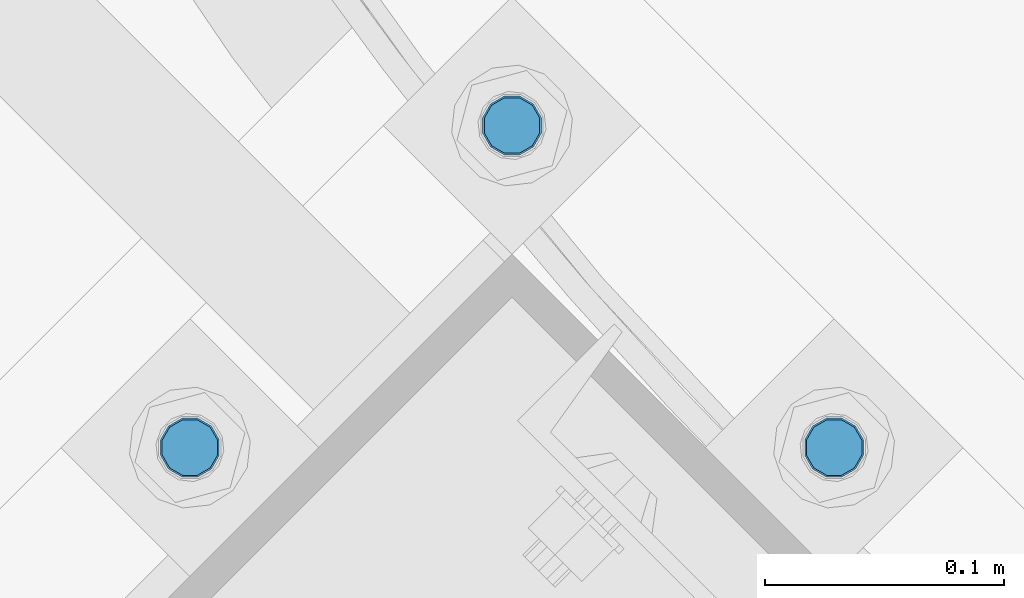
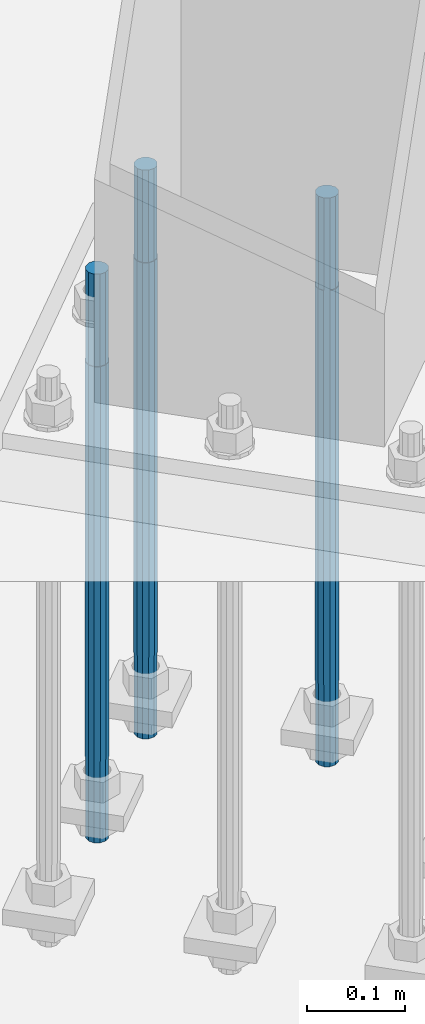
# One storey, part 781 of 1876: 3 columns, 1 element without a shape of its own.
"""IFC2X3 building model written with IfcOpenShell, lengths in millimetres."""

from ifc_helpers import new_model, si_unit, frame, origin_with_axes, place, context, subcontext, project, spatial, faceted_brep, material, type_object, element, aggregate, save


model = new_model("IFC2X3")

# Units and contexts
model_context = context("Model", 3, precision=1e-05, world=origin_with_axes())
body_context = subcontext(model_context, "Body", "Model", "MODEL_VIEW")
ifc_project = project(units=[si_unit("LENGTHUNIT", "METRE", prefix="MILLI"), si_unit("AREAUNIT", "SQUARE_METRE"), si_unit("VOLUMEUNIT", "CUBIC_METRE"), si_unit("MASSUNIT", "GRAM", prefix="KILO"), si_unit("TIMEUNIT", "SECOND"), si_unit("PLANEANGLEUNIT", "RADIAN"), si_unit("SOLIDANGLEUNIT", "STERADIAN"), si_unit("THERMODYNAMICTEMPERATUREUNIT", "DEGREE_CELSIUS"), si_unit("LUMINOUSINTENSITYUNIT", "LUMEN")], contexts=[model_context])

# Site, building, storey
site_placement = place(None, origin_with_axes())
site = spatial("IfcSite", under=ifc_project, at=site_placement, CompositionType="ELEMENT")
building_placement = place(site_placement, origin_with_axes())
building = spatial("IfcBuilding", under=site, at=building_placement, Name="Undefined", CompositionType="ELEMENT")
storey_placement = place(building_placement, origin_with_axes())
storey = spatial("IfcBuildingStorey", under=building, at=storey_placement, Name="Undefined", CompositionType="ELEMENT", Elevation=0.0)

# Assembly, columns
assembly_placement = place(storey_placement, origin_with_axes())
assembly = element("IfcElementAssembly", 1, at=assembly_placement, inside=storey, Name="TEMPLATE", AssemblyPlace="NOTDEFINED", PredefinedType="RIGID_FRAME")
ifc_material = material(Name="STEEL/F1554-GR.105")
column_type = type_object("IfcColumnType", PredefinedType="NOTDEFINED")
column_1_placement = place(assembly_placement, frame((3917.62601588898, -14852.9739841116, 7.105427357601e-15), z_axis=(0.707106781186548, 0.707106781186547, 0.0), x_axis=(0.0, 0.0, -1.0)))
column_1 = element("IfcColumn", 2, at=column_1_placement, type_object=column_type, material=ifc_material, Name="ANCHOR_BOLTS", context=body_context, shape_type="Brep", body=[
    faceted_brep([(-114.3, -10.3923048454853, 6.0000000001337), (-114.3, -6.00000000006912, 10.3923048455481), (-114.3, -6.54836185276508e-11, 12.0000000001355), (-114.3, 5.99999999993634, 10.3923048455481), (-114.3, 10.3923048453526, 6.00000000013279), (-114.3, 11.9999999999418, 1.29148247651756e-10), (-114.3, 10.3923048453507, -5.99999999987358), (-114.3, 5.99999999993815, -10.392304845288), (-114.3, -6.54836185276508e-11, -11.9999999998781), (-114.3, -6.00000000006912, -10.3923048452889), (-114.3, -10.3923048454853, -5.99999999987358), (-114.3, -12.0000000000728, 1.28238752949983e-10), (0.0, 11.9999999999418, 1.29148247651756e-10), (0.0, 10.3923048453507, -5.99999999987358), (0.0, 5.99999999993815, -10.392304845288), (0.0, -6.54836185276508e-11, -11.9999999998781), (0.0, -6.00000000006912, -10.3923048452889), (0.0, -10.3923048454853, -5.99999999987358), (0.0, -12.0000000000728, 1.28238752949983e-10), (0.0, -10.3923048454853, 6.0000000001337), (0.0, -6.00000000006912, 10.3923048455481), (0.0, -6.54836185276508e-11, 12.0000000001355), (0.0, 5.99999999993634, 10.3923048455481), (0.0, 10.3923048453526, 6.00000000013279), (0.0, -10.998522628066, 6.35000000000218), (0.0, -6.35000000000218, 10.9985226280642), (0.0, 0.0, 12.7000000000035), (0.0, 6.34999999999854, 10.9985226280651), (0.0, 10.9985226280623, 6.35000000000218), (0.0, 12.6999999999998, 0.0), (0.0, 10.9985226280623, -6.35000000000127), (0.0, 6.34999999999854, -10.9985226280633), (0.0, 0.0, -12.7000000000016), (0.0, -6.35000000000218, -10.9985226280642), (0.0, -10.998522628066, -6.35000000000127), (0.0, -12.6999999999998, 0.0), (488.95, -12.7000000000044, 9.09494701772928e-13), (488.95, -10.998522628066, 6.35000000000218), (488.95, -6.35000000000218, 10.9985226280642), (488.95, 0.0, 12.7000000000035), (488.95, 6.34999999999854, 10.9985226280651), (488.95, 10.9985226280623, 6.35000000000218), (488.95, 12.7000000000007, 9.09494701772928e-13), (488.95, 10.9985226280623, -6.35000000000127), (488.95, 6.34999999999854, -10.9985226280633), (488.95, 0.0, -12.7000000000016), (488.95, -6.35000000000218, -10.9985226280642), (488.95, -10.998522628066, -6.35000000000127), (488.95, -6.00000000006912, 10.3923048455481), (488.95, -6.54836185276508e-11, 12.0000000001355), (488.95, 5.99999999993634, 10.3923048455481), (488.95, 10.3923048453526, 6.00000000013279), (488.95, 11.9999999999418, 1.29148247651756e-10), (488.95, 10.3923048453507, -5.99999999987358), (488.95, 5.99999999993815, -10.392304845288), (488.95, -6.54836185276508e-11, -11.9999999998781), (488.95, -6.00000000006912, -10.3923048452889), (488.95, -10.3923048454853, -5.99999999987358), (488.95, -12.0000000000728, 1.28238752949983e-10), (488.95, -10.3923048454853, 6.0000000001337), (590.55, -6.00000000006912, -10.3923048452889), (590.55, -6.54836185276508e-11, -11.9999999998781), (590.55, 5.99999999993815, -10.392304845288), (590.55, 10.3923048453507, -5.99999999987358), (590.55, 11.9999999999418, 1.29148247651756e-10), (590.55, 10.3923048453526, 6.00000000013279), (590.55, 5.99999999993634, 10.3923048455481), (590.55, -6.54836185276508e-11, 12.0000000001355), (590.55, -6.00000000006912, 10.3923048455481), (590.55, -10.3923048454853, 6.0000000001337), (590.55, -12.0000000000728, 1.28238752949983e-10), (590.55, -10.3923048454853, -5.99999999987358)], [[[0, 1, 2, 3, 4, 5, 6, 7, 8, 9, 10, 11]], [[6, 5, 12, 13]], [[7, 6, 13, 14]], [[8, 7, 14, 15]], [[9, 8, 15, 16]], [[10, 9, 16, 17]], [[11, 10, 17, 18]], [[0, 11, 18, 19]], [[1, 0, 19, 20]], [[2, 1, 20, 21]], [[3, 2, 21, 22]], [[4, 3, 22, 23]], [[5, 4, 23, 12]], [[24, 25, 26, 27, 28, 29, 30, 31, 32, 33, 34, 35], [22, 21, 20, 19, 18, 17, 16, 15, 14, 13, 12, 23]], [[24, 35, 36, 37]], [[25, 24, 37, 38]], [[26, 25, 38, 39]], [[27, 26, 39, 40]], [[28, 27, 40, 41]], [[29, 28, 41, 42]], [[30, 29, 42, 43]], [[31, 30, 43, 44]], [[32, 31, 44, 45]], [[33, 32, 45, 46]], [[34, 33, 46, 47]], [[35, 34, 47, 36]], [[46, 45, 44, 43, 42, 41, 40, 39, 38, 37, 36, 47], [48, 49, 50, 51, 52, 53, 54, 55, 56, 57, 58, 59]], [[60, 61, 62, 63, 64, 65, 66, 67, 68, 69, 70, 71]], [[68, 67, 49, 48]], [[69, 68, 48, 59]], [[70, 69, 59, 58]], [[71, 70, 58, 57]], [[60, 71, 57, 56]], [[61, 60, 56, 55]], [[62, 61, 55, 54]], [[63, 62, 54, 53]], [[64, 63, 53, 52]], [[65, 64, 52, 51]], [[66, 65, 51, 50]], [[67, 66, 50, 49]]]),
])
column_2_placement = place(assembly_placement, frame((3782.9221740726, -14718.2701422952, 7.105427357601e-15), z_axis=(-0.707106781186547, -0.707106781186548, 0.0), x_axis=(0.0, 0.0, -1.0)))
column_2 = element("IfcColumn", 3, at=column_2_placement, type_object=column_type, material=ifc_material, Name="ANCHOR_BOLTS", context=body_context, shape_type="Brep", body=[
    faceted_brep([(-114.3, -10.3923048454853, 6.0000000001337), (-114.3, -6.00000000006912, 10.3923048455481), (-114.3, -6.54836185276508e-11, 12.0000000001355), (-114.3, 5.99999999993634, 10.3923048455481), (-114.3, 10.3923048453526, 6.00000000013279), (-114.3, 11.9999999999418, 1.29148247651756e-10), (-114.3, 10.3923048453507, -5.99999999987358), (-114.3, 5.99999999993815, -10.392304845288), (-114.3, -6.54836185276508e-11, -11.9999999998781), (-114.3, -6.00000000006912, -10.3923048452889), (-114.3, -10.3923048454853, -5.99999999987358), (-114.3, -12.0000000000728, 1.28238752949983e-10), (0.0, 11.9999999999418, 1.29148247651756e-10), (0.0, 10.3923048453507, -5.99999999987358), (0.0, 5.99999999993815, -10.392304845288), (0.0, -6.54836185276508e-11, -11.9999999998781), (0.0, -6.00000000006912, -10.3923048452889), (0.0, -10.3923048454853, -5.99999999987358), (0.0, -12.0000000000728, 1.28238752949983e-10), (0.0, -10.3923048454853, 6.0000000001337), (0.0, -6.00000000006912, 10.3923048455481), (0.0, -6.54836185276508e-11, 12.0000000001355), (0.0, 5.99999999993634, 10.3923048455481), (0.0, 10.3923048453526, 6.00000000013279), (0.0, -10.998522628066, 6.35000000000218), (0.0, -6.35000000000218, 10.9985226280642), (0.0, 0.0, 12.7000000000035), (0.0, 6.34999999999854, 10.9985226280651), (0.0, 10.9985226280623, 6.35000000000218), (0.0, 12.6999999999998, 0.0), (0.0, 10.9985226280623, -6.35000000000127), (0.0, 6.34999999999854, -10.9985226280633), (0.0, 0.0, -12.7000000000016), (0.0, -6.35000000000218, -10.9985226280642), (0.0, -10.998522628066, -6.35000000000127), (0.0, -12.6999999999998, 0.0), (488.95, -12.7000000000044, 9.09494701772928e-13), (488.95, -10.998522628066, 6.35000000000218), (488.95, -6.35000000000218, 10.9985226280642), (488.95, 0.0, 12.7000000000035), (488.95, 6.34999999999854, 10.9985226280651), (488.95, 10.9985226280623, 6.35000000000218), (488.95, 12.7000000000007, 9.09494701772928e-13), (488.95, 10.9985226280623, -6.35000000000127), (488.95, 6.34999999999854, -10.9985226280633), (488.95, 0.0, -12.7000000000016), (488.95, -6.35000000000218, -10.9985226280642), (488.95, -10.998522628066, -6.35000000000127), (488.95, -6.00000000006912, 10.3923048455481), (488.95, -6.54836185276508e-11, 12.0000000001355), (488.95, 5.99999999993634, 10.3923048455481), (488.95, 10.3923048453526, 6.00000000013279), (488.95, 11.9999999999418, 1.29148247651756e-10), (488.95, 10.3923048453507, -5.99999999987358), (488.95, 5.99999999993815, -10.392304845288), (488.95, -6.54836185276508e-11, -11.9999999998781), (488.95, -6.00000000006912, -10.3923048452889), (488.95, -10.3923048454853, -5.99999999987358), (488.95, -12.0000000000728, 1.28238752949983e-10), (488.95, -10.3923048454853, 6.0000000001337), (590.55, -6.00000000006912, -10.3923048452889), (590.55, -6.54836185276508e-11, -11.9999999998781), (590.55, 5.99999999993815, -10.392304845288), (590.55, 10.3923048453507, -5.99999999987358), (590.55, 11.9999999999418, 1.29148247651756e-10), (590.55, 10.3923048453526, 6.00000000013279), (590.55, 5.99999999993634, 10.3923048455481), (590.55, -6.54836185276508e-11, 12.0000000001355), (590.55, -6.00000000006912, 10.3923048455481), (590.55, -10.3923048454853, 6.0000000001337), (590.55, -12.0000000000728, 1.28238752949983e-10), (590.55, -10.3923048454853, -5.99999999987358)], [[[0, 1, 2, 3, 4, 5, 6, 7, 8, 9, 10, 11]], [[6, 5, 12, 13]], [[7, 6, 13, 14]], [[8, 7, 14, 15]], [[9, 8, 15, 16]], [[10, 9, 16, 17]], [[11, 10, 17, 18]], [[0, 11, 18, 19]], [[1, 0, 19, 20]], [[2, 1, 20, 21]], [[3, 2, 21, 22]], [[4, 3, 22, 23]], [[5, 4, 23, 12]], [[24, 25, 26, 27, 28, 29, 30, 31, 32, 33, 34, 35], [22, 21, 20, 19, 18, 17, 16, 15, 14, 13, 12, 23]], [[24, 35, 36, 37]], [[25, 24, 37, 38]], [[26, 25, 38, 39]], [[27, 26, 39, 40]], [[28, 27, 40, 41]], [[29, 28, 41, 42]], [[30, 29, 42, 43]], [[31, 30, 43, 44]], [[32, 31, 44, 45]], [[33, 32, 45, 46]], [[34, 33, 46, 47]], [[35, 34, 47, 36]], [[46, 45, 44, 43, 42, 41, 40, 39, 38, 37, 36, 47], [48, 49, 50, 51, 52, 53, 54, 55, 56, 57, 58, 59]], [[60, 61, 62, 63, 64, 65, 66, 67, 68, 69, 70, 71]], [[68, 67, 49, 48]], [[69, 68, 48, 59]], [[70, 69, 59, 58]], [[71, 70, 58, 57]], [[60, 71, 57, 56]], [[61, 60, 56, 55]], [[62, 61, 55, 54]], [[63, 62, 54, 53]], [[64, 63, 53, 52]], [[65, 64, 52, 51]], [[66, 65, 51, 50]], [[67, 66, 50, 49]]]),
])
column_3_placement = place(assembly_placement, frame((3648.21833225621, -14852.9739841116, 7.105427357601e-15), z_axis=(-0.707106781186547, -0.707106781186548, 0.0), x_axis=(0.0, 0.0, -1.0)))
column_3 = element("IfcColumn", 4, at=column_3_placement, type_object=column_type, material=ifc_material, Name="ANCHOR_BOLTS", context=body_context, shape_type="Brep", body=[
    faceted_brep([(-114.3, -10.3923048454853, 6.0000000001337), (-114.3, -6.00000000006912, 10.3923048455481), (-114.3, -6.54836185276508e-11, 12.0000000001355), (-114.3, 5.99999999993634, 10.3923048455481), (-114.3, 10.3923048453526, 6.00000000013279), (-114.3, 11.9999999999418, 1.29148247651756e-10), (-114.3, 10.3923048453507, -5.99999999987358), (-114.3, 5.99999999993815, -10.392304845288), (-114.3, -6.54836185276508e-11, -11.9999999998781), (-114.3, -6.00000000006912, -10.3923048452889), (-114.3, -10.3923048454853, -5.99999999987358), (-114.3, -12.0000000000728, 1.28238752949983e-10), (0.0, 11.9999999999418, 1.29148247651756e-10), (0.0, 10.3923048453507, -5.99999999987358), (0.0, 5.99999999993815, -10.392304845288), (0.0, -6.54836185276508e-11, -11.9999999998781), (0.0, -6.00000000006912, -10.3923048452889), (0.0, -10.3923048454853, -5.99999999987358), (0.0, -12.0000000000728, 1.28238752949983e-10), (0.0, -10.3923048454853, 6.0000000001337), (0.0, -6.00000000006912, 10.3923048455481), (0.0, -6.54836185276508e-11, 12.0000000001355), (0.0, 5.99999999993634, 10.3923048455481), (0.0, 10.3923048453526, 6.00000000013279), (0.0, -10.998522628066, 6.35000000000218), (0.0, -6.35000000000218, 10.9985226280642), (0.0, 0.0, 12.7000000000035), (0.0, 6.34999999999854, 10.9985226280651), (0.0, 10.9985226280623, 6.35000000000218), (0.0, 12.6999999999998, 0.0), (0.0, 10.9985226280623, -6.35000000000127), (0.0, 6.34999999999854, -10.9985226280633), (0.0, 0.0, -12.7000000000016), (0.0, -6.35000000000218, -10.9985226280642), (0.0, -10.998522628066, -6.35000000000127), (0.0, -12.6999999999998, 0.0), (488.95, -12.7000000000044, 9.09494701772928e-13), (488.95, -10.998522628066, 6.35000000000218), (488.95, -6.35000000000218, 10.9985226280642), (488.95, 0.0, 12.7000000000035), (488.95, 6.34999999999854, 10.9985226280651), (488.95, 10.9985226280623, 6.35000000000218), (488.95, 12.7000000000007, 9.09494701772928e-13), (488.95, 10.9985226280623, -6.35000000000127), (488.95, 6.34999999999854, -10.9985226280633), (488.95, 0.0, -12.7000000000016), (488.95, -6.35000000000218, -10.9985226280642), (488.95, -10.998522628066, -6.35000000000127), (488.95, -6.00000000006912, 10.3923048455481), (488.95, -6.54836185276508e-11, 12.0000000001355), (488.95, 5.99999999993634, 10.3923048455481), (488.95, 10.3923048453526, 6.00000000013279), (488.95, 11.9999999999418, 1.29148247651756e-10), (488.95, 10.3923048453507, -5.99999999987358), (488.95, 5.99999999993815, -10.392304845288), (488.95, -6.54836185276508e-11, -11.9999999998781), (488.95, -6.00000000006912, -10.3923048452889), (488.95, -10.3923048454853, -5.99999999987358), (488.95, -12.0000000000728, 1.28238752949983e-10), (488.95, -10.3923048454853, 6.0000000001337), (590.55, -6.00000000006912, -10.3923048452889), (590.55, -6.54836185276508e-11, -11.9999999998781), (590.55, 5.99999999993815, -10.392304845288), (590.55, 10.3923048453507, -5.99999999987358), (590.55, 11.9999999999418, 1.29148247651756e-10), (590.55, 10.3923048453526, 6.00000000013279), (590.55, 5.99999999993634, 10.3923048455481), (590.55, -6.54836185276508e-11, 12.0000000001355), (590.55, -6.00000000006912, 10.3923048455481), (590.55, -10.3923048454853, 6.0000000001337), (590.55, -12.0000000000728, 1.28238752949983e-10), (590.55, -10.3923048454853, -5.99999999987358)], [[[0, 1, 2, 3, 4, 5, 6, 7, 8, 9, 10, 11]], [[6, 5, 12, 13]], [[7, 6, 13, 14]], [[8, 7, 14, 15]], [[9, 8, 15, 16]], [[10, 9, 16, 17]], [[11, 10, 17, 18]], [[0, 11, 18, 19]], [[1, 0, 19, 20]], [[2, 1, 20, 21]], [[3, 2, 21, 22]], [[4, 3, 22, 23]], [[5, 4, 23, 12]], [[24, 25, 26, 27, 28, 29, 30, 31, 32, 33, 34, 35], [22, 21, 20, 19, 18, 17, 16, 15, 14, 13, 12, 23]], [[24, 35, 36, 37]], [[25, 24, 37, 38]], [[26, 25, 38, 39]], [[27, 26, 39, 40]], [[28, 27, 40, 41]], [[29, 28, 41, 42]], [[30, 29, 42, 43]], [[31, 30, 43, 44]], [[32, 31, 44, 45]], [[33, 32, 45, 46]], [[34, 33, 46, 47]], [[35, 34, 47, 36]], [[46, 45, 44, 43, 42, 41, 40, 39, 38, 37, 36, 47], [48, 49, 50, 51, 52, 53, 54, 55, 56, 57, 58, 59]], [[60, 61, 62, 63, 64, 65, 66, 67, 68, 69, 70, 71]], [[68, 67, 49, 48]], [[69, 68, 48, 59]], [[70, 69, 59, 58]], [[71, 70, 58, 57]], [[60, 71, 57, 56]], [[61, 60, 56, 55]], [[62, 61, 55, 54]], [[63, 62, 54, 53]], [[64, 63, 53, 52]], [[65, 64, 52, 51]], [[66, 65, 51, 50]], [[67, 66, 50, 49]]]),
])
aggregate(assembly, [column_1, column_2, column_3])

save(model, "model.ifc")
